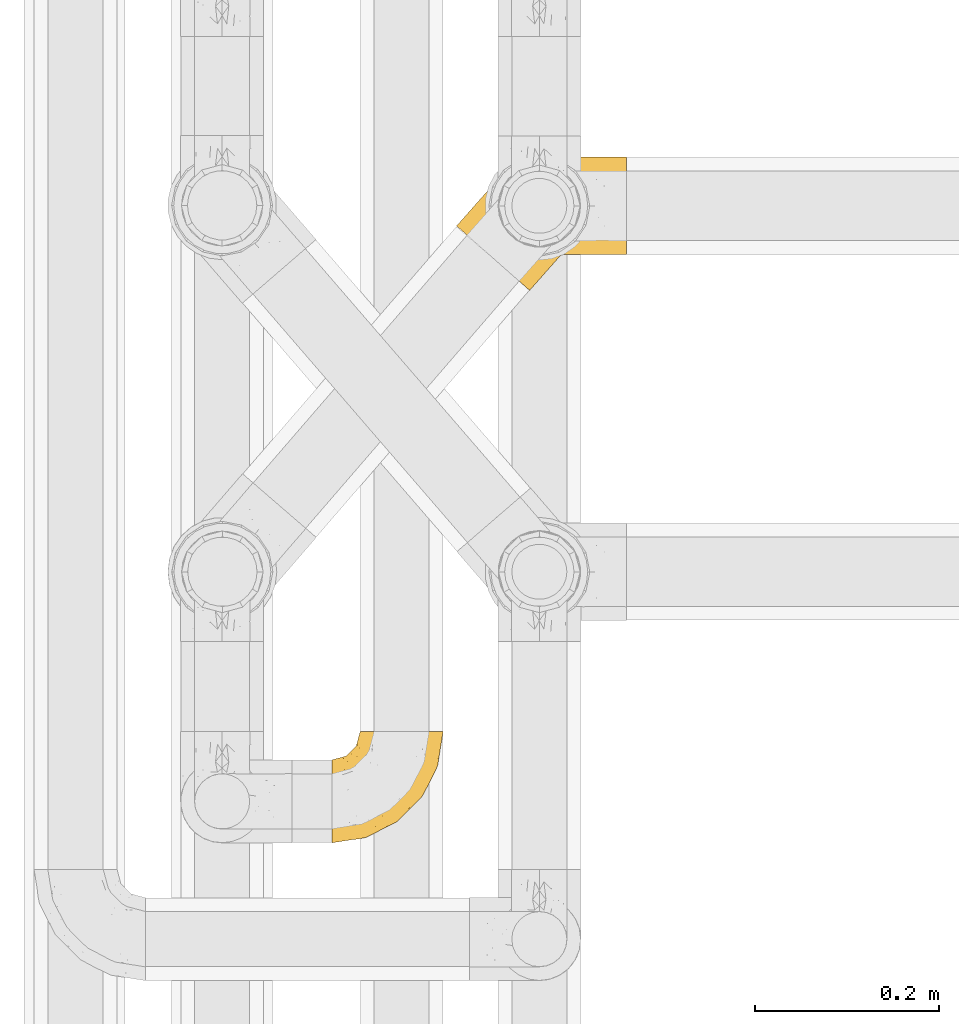
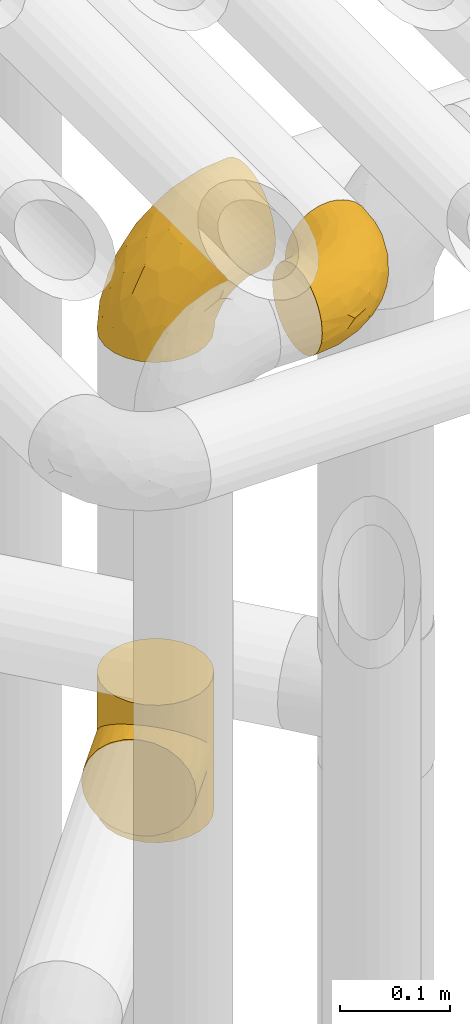
# One storey, part 232 of 827: 3 coverings.
"""IFC2X3 building model written with IfcOpenShell, lengths in millimetres."""

from ifc_helpers import new_model, entity, si_unit, converted_unit, derived_unit, direction, frame, origin, place, context, subcontext, project, spatial, faceted_brep, element, save


model = new_model("IFC2X3")

# Units and contexts
model_context = context("Model", 3, precision=0.01, world=origin(), true_north=direction((6.12303176911189e-17, 1.0)))
body_context = subcontext(model_context, "Body", "Model", "MODEL_VIEW")
ifc_project = project(units=[si_unit("LENGTHUNIT", "METRE", prefix="MILLI"), si_unit("AREAUNIT", "SQUARE_METRE"), si_unit("VOLUMEUNIT", "CUBIC_METRE"), converted_unit("PLANEANGLEUNIT", "DEGREE", entity("IfcRatioMeasure", 0.0174532925199433), si_unit("PLANEANGLEUNIT", "RADIAN"), dimensions=[0, 0, 0, 0, 0, 0, 0]), si_unit("MASSUNIT", "GRAM", prefix="KILO"), derived_unit("MASSDENSITYUNIT", [(si_unit("MASSUNIT", "GRAM", prefix="KILO"), 1), (si_unit("LENGTHUNIT", "METRE"), -3)]), derived_unit("MOMENTOFINERTIAUNIT", [(si_unit("LENGTHUNIT", "METRE"), 4)]), si_unit("TIMEUNIT", "SECOND"), si_unit("FREQUENCYUNIT", "HERTZ"), si_unit("THERMODYNAMICTEMPERATUREUNIT", "DEGREE_CELSIUS"), derived_unit("THERMALTRANSMITTANCEUNIT", [(si_unit("MASSUNIT", "GRAM", prefix="KILO"), 1), (si_unit("THERMODYNAMICTEMPERATUREUNIT", "KELVIN"), -1), (si_unit("TIMEUNIT", "SECOND"), -3)]), derived_unit("VOLUMETRICFLOWRATEUNIT", [(si_unit("LENGTHUNIT", "METRE"), 3), (si_unit("TIMEUNIT", "SECOND"), -1)]), derived_unit("MASSFLOWRATEUNIT", [(si_unit("MASSUNIT", "GRAM", prefix="KILO"), 1), (si_unit("TIMEUNIT", "SECOND"), -1)]), derived_unit("ROTATIONALFREQUENCYUNIT", [(si_unit("TIMEUNIT", "SECOND"), -1)]), si_unit("ELECTRICCURRENTUNIT", "AMPERE"), si_unit("ELECTRICVOLTAGEUNIT", "VOLT"), si_unit("POWERUNIT", "WATT"), si_unit("FORCEUNIT", "NEWTON", prefix="KILO"), si_unit("ILLUMINANCEUNIT", "LUX"), si_unit("LUMINOUSFLUXUNIT", "LUMEN"), si_unit("LUMINOUSINTENSITYUNIT", "CANDELA"), derived_unit("USERDEFINED", [(si_unit("MASSUNIT", "GRAM", prefix="KILO"), -1), (si_unit("LENGTHUNIT", "METRE"), -2), (si_unit("TIMEUNIT", "SECOND"), 3), (si_unit("LUMINOUSFLUXUNIT", "LUMEN"), 1)]), derived_unit("LINEARVELOCITYUNIT", [(si_unit("LENGTHUNIT", "METRE"), 1), (si_unit("TIMEUNIT", "SECOND"), -1)]), si_unit("PRESSUREUNIT", "PASCAL"), derived_unit("USERDEFINED", [(si_unit("LENGTHUNIT", "METRE"), -2), (si_unit("MASSUNIT", "GRAM", prefix="KILO"), 1), (si_unit("TIMEUNIT", "SECOND"), -2)]), derived_unit("LINEARFORCEUNIT", [(si_unit("MASSUNIT", "GRAM", prefix="KILO"), 1), (si_unit("LENGTHUNIT", "METRE"), 1), (si_unit("TIMEUNIT", "SECOND"), -2), (si_unit("LENGTHUNIT", "METRE"), -1)]), derived_unit("PLANARFORCEUNIT", [(si_unit("MASSUNIT", "GRAM", prefix="KILO"), 1), (si_unit("LENGTHUNIT", "METRE"), 1), (si_unit("TIMEUNIT", "SECOND"), -2), (si_unit("LENGTHUNIT", "METRE"), -2)])], contexts=[model_context])

# Site, building, storey
site_placement = place(None, origin())
site = spatial("IfcSite", under=ifc_project, at=site_placement, CompositionType="ELEMENT")
building_placement = place(site_placement, origin())
building = spatial("IfcBuilding", under=site, at=building_placement, CompositionType="ELEMENT")
storey_placement = place(building_placement, frame((0.0, 0.0, 28200.0)))
storey = spatial("IfcBuildingStorey", under=building, at=storey_placement, Name="08", CompositionType="ELEMENT", Elevation=28200.0)

# Coverings
covering_1_placement = place(storey_placement, frame((36747.44, 12284.43, 2953.25)))
element("IfcCovering", 1, at=covering_1_placement, inside=storey, Name=":ADSK_", ObjectType=":ADSK_", PredefinedType="INSULATION", context=body_context, shape_type="Brep", body=[
    faceted_brep([(87.65, 122.75, 90.76), (97.19, 122.75, 87.42), (105.75, 122.75, 82.04), (112.9, 122.75, 74.89), (118.28, 122.75, 66.33), (121.61, 122.75, 56.79), (122.75, 122.75, 46.75), (121.61, 122.75, 36.69), (118.27, 122.75, 27.15), (112.89, 122.75, 18.59), (105.74, 122.75, 11.44), (97.18, 122.75, 6.06), (87.64, 122.75, 2.73), (77.6, 122.75, 1.6), (67.54, 122.75, 2.73), (58.0, 122.75, 6.07), (49.44, 122.75, 11.45), (42.29, 122.75, 18.6), (36.91, 122.75, 27.16), (33.58, 122.75, 36.7), (32.45, 122.75, 46.75), (33.58, 122.75, 56.8), (36.92, 122.75, 66.34), (42.3, 122.75, 74.9), (49.45, 122.75, 82.05), (58.01, 122.75, 87.43), (67.55, 122.75, 90.76), (77.6, 122.75, 91.9), (1.6, 90.36, 35.06), (1.6, 85.85, 24.17), (1.6, 78.67, 14.82), (1.6, 69.32, 7.64), (1.6, 58.43, 3.13), (1.6, 46.75, 1.6), (1.6, 35.06, 3.13), (1.6, 24.17, 7.64), (1.6, 14.82, 14.82), (1.6, 7.64, 24.17), (1.6, 3.13, 35.06), (1.6, 1.6, 46.75), (1.6, 3.13, 58.43), (1.6, 7.64, 69.32), (1.6, 14.82, 78.67), (1.6, 24.17, 85.85), (1.6, 35.06, 90.36), (1.6, 46.75, 91.9), (1.6, 58.43, 90.36), (1.6, 69.32, 85.85), (1.6, 78.67, 78.67), (1.6, 85.85, 69.32), (1.6, 90.36, 58.43), (1.6, 91.9, 46.75), (99.61, 51.54, 46.75), (95.26, 47.17, 55.2), (86.21, 38.13, 46.75), (39.03, 7.52, 46.75), (30.75, 5.85, 54.53), (23.8, 5.11, 46.75), (60.8, 19.2, 59.63), (85.37, 38.98, 62.07), (73.64, 35.02, 71.86), (31.01, 8.21, 62.65), (49.14, 19.28, 71.33), (23.88, 12.19, 72.93), (82.74, 101.39, 91.2), (43.48, 34.43, 86.31), (29.47, 20.95, 80.89), (56.38, 30.74, 79.49), (72.18, 72.93, 90.68), (72.24, 56.64, 86.84), (87.6, 80.81, 87.38), (107.24, 93.43, 76.87), (101.1, 100.76, 83.73), (95.16, 74.27, 81.03), (71.81, 93.66, 91.9), (63.57, 81.33, 91.9), (55.34, 69.01, 91.9), (23.66, 40.87, 91.03), (20.55, 29.38, 87.58), (107.97, 67.05, 56.52), (116.82, 85.31, 46.75), (117.03, 93.68, 60.4), (30.68, 52.53, 91.9), (21.51, 50.71, 91.9), (12.33, 48.88, 91.9), (106.17, 72.77, 67.87), (52.37, 51.21, 90.35), (114.51, 101.18, 69.57), (119.23, 100.54, 46.75), (78.37, 48.74, 79.91), (75.46, 112.01, 91.9), (73.63, 102.83, 91.9), (101.51, 73.88, 74.99), (72.81, 24.73, 46.75), (43.01, 60.77, 91.9), (92.6, 103.08, 88.53), (91.86, 54.8, 72.65), (55.92, 16.13, 46.75), (99.01, 55.92, 62.97), (108.21, 68.42, 46.75), (32.05, 104.98, 66.2), (30.22, 108.58, 56.6), (23.37, 98.21, 59.89), (28.43, 61.56, 90.95), (16.44, 60.69, 90.22), (37.1, 100.0, 76.64), (28.88, 95.88, 71.58), (33.93, 90.81, 79.99), (50.17, 84.88, 89.54), (40.57, 73.29, 89.97), (47.62, 113.4, 81.32), (39.9, 109.8, 74.56), (47.92, 102.13, 84.15), (34.27, 67.29, 90.37), (24.65, 70.34, 87.82), (62.6, 95.15, 90.98), (66.18, 105.49, 90.96), (11.74, 71.5, 85.14), (13.89, 92.87, 58.11), (17.02, 96.03, 46.75), (15.86, 81.34, 78.39), (57.71, 107.44, 88.22), (9.11, 88.36, 66.06), (18.55, 90.43, 68.6), (34.74, 114.37, 63.78), (54.95, 98.41, 88.42), (57.35, 88.73, 90.61), (22.03, 76.89, 83.8), (24.8, 86.08, 77.98), (69.07, 112.64, 91.22), (42.31, 94.21, 83.46), (29.63, 112.22, 46.75), (28.31, 107.32, 46.75), (30.23, 79.95, 84.66), (40.13, 84.51, 86.33), (22.67, 101.67, 46.75), (12.12, 94.71, 46.75), (15.86, 81.34, 15.1), (22.03, 76.89, 9.69), (24.8, 86.08, 15.52), (30.23, 79.96, 8.83), (13.88, 92.87, 35.39), (47.61, 113.41, 12.18), (73.63, 102.83, 1.6), (66.17, 105.5, 2.53), (69.07, 112.64, 2.27), (30.22, 108.58, 36.9), (32.04, 104.98, 27.31), (23.36, 98.2, 33.62), (54.93, 98.4, 5.07), (47.91, 102.13, 9.36), (57.69, 107.44, 5.27), (9.1, 88.36, 27.43), (21.51, 50.71, 1.6), (12.33, 48.88, 1.6), (42.29, 94.22, 10.05), (37.09, 100.01, 16.87), (11.74, 71.5, 8.35), (16.44, 60.69, 3.27), (30.68, 52.53, 1.6), (28.86, 95.89, 21.94), (34.74, 114.37, 29.72), (63.57, 81.33, 1.6), (55.34, 69.01, 1.6), (50.17, 84.88, 3.96), (75.46, 112.01, 1.6), (39.89, 109.8, 18.95), (28.43, 61.56, 2.54), (34.27, 67.29, 3.12), (43.01, 60.77, 1.6), (62.59, 95.14, 2.51), (40.57, 73.29, 3.52), (40.13, 84.53, 7.17), (71.81, 93.66, 1.6), (33.92, 90.82, 13.52), (57.34, 88.73, 2.88), (24.65, 70.34, 5.67), (18.54, 90.43, 24.89), (29.47, 20.95, 12.6), (43.48, 34.43, 7.18), (56.4, 30.74, 14.0), (49.17, 19.29, 22.16), (73.69, 35.07, 21.61), (52.37, 51.21, 3.14), (72.26, 56.67, 6.65), (91.88, 54.85, 20.82), (85.36, 38.98, 31.41), (20.55, 29.38, 5.91), (23.66, 40.87, 2.46), (60.8, 19.2, 33.87), (31.02, 8.21, 30.84), (30.75, 5.85, 38.96), (23.9, 12.19, 20.56), (72.17, 72.93, 2.81), (87.59, 80.83, 6.1), (82.74, 101.39, 2.29), (117.03, 93.69, 33.08), (107.23, 93.43, 16.61), (107.97, 67.04, 36.96), (101.08, 100.76, 9.75), (106.17, 72.78, 25.61), (99.01, 55.93, 30.5), (114.5, 101.18, 23.91), (95.15, 74.27, 12.45), (101.5, 73.89, 18.49), (92.59, 103.09, 4.96), (78.38, 48.78, 13.56), (95.27, 47.19, 38.28)], [[[0, 1, 2, 3, 4, 5, 6, 7, 8, 9, 10, 11, 12, 13, 14, 15, 16, 17, 18, 19, 20, 21, 22, 23, 24, 25, 26, 27]], [[28, 29, 30, 31, 32, 33, 34, 35, 36, 37, 38, 39, 40, 41, 42, 43, 44, 45, 46, 47, 48, 49, 50, 51]], [[52, 53, 54]], [[55, 56, 57]], [[58, 59, 60]], [[61, 62, 63]], [[27, 64, 0]], [[65, 66, 67]], [[41, 40, 61]], [[68, 69, 70]], [[66, 43, 42]], [[63, 42, 41]], [[71, 72, 73]], [[72, 2, 1]], [[68, 74, 75, 76]], [[45, 44, 77]], [[43, 78, 44]], [[79, 80, 81]], [[77, 82, 83, 84, 45]], [[79, 81, 85]], [[71, 2, 72]], [[65, 86, 77]], [[4, 81, 5]], [[66, 65, 78]], [[4, 3, 87]], [[81, 88, 5]], [[63, 66, 42]], [[68, 70, 64]], [[67, 60, 89]], [[71, 3, 2]], [[64, 27, 90, 91, 74]], [[92, 71, 73]], [[40, 57, 56]], [[59, 93, 54]], [[86, 76, 94, 82]], [[1, 0, 95]], [[58, 62, 61]], [[60, 96, 89]], [[85, 81, 87]], [[56, 97, 58]], [[65, 67, 69]], [[87, 81, 4]], [[67, 89, 69]], [[61, 63, 41]], [[95, 72, 1]], [[73, 72, 70]], [[69, 73, 70]], [[73, 89, 96]], [[3, 71, 87]], [[85, 87, 71]], [[58, 61, 56]], [[59, 58, 93]], [[76, 86, 68]], [[69, 89, 73]], [[68, 86, 69]], [[65, 69, 86]], [[68, 64, 74]], [[95, 64, 70]], [[98, 79, 85]], [[79, 52, 99, 80]], [[66, 62, 67]], [[62, 58, 60]], [[62, 60, 67]], [[59, 98, 96]], [[59, 96, 60]], [[96, 85, 92]], [[88, 81, 80]], [[88, 6, 5]], [[66, 63, 62]], [[64, 95, 0]], [[72, 95, 70]], [[77, 44, 78]], [[86, 82, 77]], [[40, 39, 57]], [[96, 98, 85]], [[40, 56, 61]], [[66, 78, 43]], [[77, 78, 65]], [[79, 98, 53]], [[96, 92, 73]], [[85, 71, 92]], [[97, 56, 55]], [[97, 93, 58]], [[53, 98, 59]], [[54, 53, 59]], [[79, 53, 52]], [[100, 101, 102]], [[46, 45, 84, 83]], [[103, 104, 82]], [[82, 104, 83]], [[105, 106, 107]], [[108, 109, 76]], [[110, 111, 112]], [[103, 113, 114]], [[115, 74, 116]], [[48, 47, 117]], [[118, 102, 119]], [[49, 48, 120]], [[74, 91, 116]], [[116, 121, 115]], [[49, 122, 50]], [[123, 106, 102]], [[124, 111, 22]], [[125, 126, 115]], [[23, 22, 111]], [[24, 110, 121]], [[120, 127, 128]], [[90, 26, 129]], [[27, 26, 90]], [[121, 125, 115]], [[24, 121, 25]], [[130, 105, 107]], [[129, 25, 116]], [[21, 20, 131]], [[120, 123, 122]], [[112, 105, 130]], [[50, 118, 51]], [[21, 124, 22]], [[101, 131, 132]], [[117, 120, 48]], [[24, 23, 110]], [[127, 114, 133]], [[75, 108, 76]], [[107, 134, 130]], [[133, 114, 113]], [[129, 116, 91]], [[25, 121, 116]], [[121, 112, 125]], [[75, 74, 115]], [[101, 135, 102]], [[131, 101, 21]], [[101, 100, 124]], [[128, 127, 133]], [[119, 136, 51, 118]], [[104, 47, 46]], [[83, 104, 46]], [[117, 104, 114]], [[101, 124, 21]], [[111, 124, 100]], [[102, 118, 123]], [[133, 134, 107]], [[111, 110, 23]], [[114, 104, 103]], [[94, 76, 109]], [[121, 110, 112]], [[122, 118, 50]], [[134, 109, 108]], [[133, 107, 128]], [[112, 108, 125]], [[126, 125, 108]], [[108, 75, 126]], [[75, 115, 126]], [[109, 134, 133]], [[130, 108, 112]], [[108, 130, 134]], [[105, 112, 111]], [[111, 100, 105]], [[106, 105, 100]], [[102, 106, 100]], [[128, 106, 123]], [[90, 129, 91]], [[25, 129, 26]], [[104, 117, 47]], [[117, 114, 127]], [[82, 94, 103]], [[113, 94, 109]], [[94, 113, 103]], [[133, 113, 109]], [[106, 128, 107]], [[123, 120, 128]], [[120, 122, 49]], [[118, 122, 123]], [[135, 101, 132]], [[135, 119, 102]], [[117, 127, 120]], [[30, 29, 137]], [[138, 139, 140]], [[51, 136, 119, 141]], [[142, 17, 16]], [[143, 144, 145]], [[146, 147, 148]], [[149, 150, 151]], [[152, 29, 28]], [[33, 32, 153, 154]], [[150, 155, 156]], [[157, 31, 30]], [[153, 158, 159]], [[29, 152, 137]], [[148, 141, 119]], [[156, 160, 147]], [[148, 135, 146]], [[137, 138, 157]], [[19, 161, 146]], [[162, 163, 164]], [[14, 13, 165]], [[153, 32, 158]], [[147, 161, 166]], [[18, 17, 166]], [[167, 168, 169]], [[166, 150, 156]], [[151, 150, 142]], [[151, 170, 149]], [[151, 16, 15]], [[171, 140, 172]], [[165, 143, 145]], [[173, 170, 144]], [[142, 166, 17]], [[19, 131, 20]], [[144, 170, 151]], [[18, 161, 19]], [[173, 144, 143]], [[140, 139, 174]], [[171, 164, 163]], [[164, 172, 155]], [[151, 15, 144]], [[145, 15, 14]], [[173, 162, 170]], [[149, 175, 164]], [[19, 146, 131]], [[132, 131, 146]], [[160, 148, 147]], [[159, 158, 167]], [[135, 132, 146]], [[158, 32, 31]], [[157, 158, 31]], [[167, 158, 176]], [[166, 161, 18]], [[146, 161, 147]], [[148, 177, 141]], [[171, 168, 140]], [[171, 163, 169]], [[151, 142, 16]], [[166, 142, 150]], [[152, 141, 177]], [[51, 141, 28]], [[138, 140, 176]], [[172, 140, 174]], [[175, 149, 170]], [[164, 150, 149]], [[170, 162, 175]], [[162, 164, 175]], [[155, 172, 174]], [[171, 172, 164]], [[155, 174, 156]], [[164, 155, 150]], [[160, 156, 174]], [[147, 166, 156]], [[139, 160, 174]], [[148, 160, 177]], [[15, 145, 144]], [[165, 145, 14]], [[137, 157, 30]], [[158, 157, 176]], [[168, 167, 176]], [[169, 159, 167]], [[140, 168, 176]], [[169, 168, 171]], [[137, 177, 139]], [[160, 139, 177]], [[141, 152, 28]], [[137, 152, 177]], [[148, 119, 135]], [[157, 138, 176]], [[139, 138, 137]], [[178, 179, 180]], [[181, 180, 182]], [[179, 183, 184]], [[185, 186, 182]], [[187, 188, 179]], [[188, 33, 154, 153, 159]], [[181, 189, 190]], [[35, 34, 187]], [[191, 38, 190]], [[192, 178, 181]], [[179, 184, 180]], [[192, 190, 37]], [[37, 190, 38]], [[36, 35, 178]], [[54, 93, 186]], [[35, 187, 178]], [[193, 194, 184]], [[195, 173, 143, 165, 13]], [[195, 193, 173]], [[193, 163, 162, 173]], [[13, 12, 195]], [[8, 7, 196]], [[9, 197, 10]], [[198, 80, 99, 52]], [[196, 7, 88]], [[197, 199, 10]], [[182, 189, 181]], [[200, 198, 201]], [[200, 196, 198]], [[9, 8, 202]], [[194, 199, 203]], [[192, 37, 36]], [[80, 196, 88]], [[183, 159, 169, 163]], [[188, 34, 33]], [[202, 200, 197]], [[185, 203, 204]], [[202, 8, 196]], [[10, 199, 11]], [[12, 11, 205]], [[38, 191, 57]], [[189, 97, 191]], [[203, 199, 197]], [[205, 199, 194]], [[204, 203, 197]], [[184, 203, 206]], [[200, 202, 196]], [[197, 9, 202]], [[207, 54, 186]], [[97, 55, 191]], [[194, 203, 184]], [[183, 163, 193]], [[184, 206, 180]], [[183, 193, 184]], [[205, 195, 12]], [[193, 195, 194]], [[80, 198, 196]], [[207, 186, 201]], [[182, 180, 206]], [[181, 178, 180]], [[185, 182, 206]], [[182, 186, 189]], [[203, 185, 206]], [[185, 200, 201]], [[7, 6, 88]], [[178, 192, 36]], [[190, 192, 181]], [[199, 205, 11]], [[195, 205, 194]], [[159, 183, 188]], [[179, 188, 183]], [[57, 191, 55]], [[57, 39, 38]], [[189, 191, 190]], [[188, 187, 34]], [[178, 187, 179]], [[186, 93, 189]], [[197, 200, 204]], [[185, 204, 200]], [[189, 93, 97]], [[207, 198, 52]], [[185, 201, 186]], [[198, 207, 201]], [[54, 207, 52]]]),
])
covering_2_placement = place(storey_placement, frame((36883.36, 12885.97, 1974.0)))
element("IfcCovering", 2, at=covering_2_placement, inside=storey, Name=":ADSK_", ObjectType=":ADSK_", PredefinedType="INSULATION", context=body_context, shape_type="Brep", body=[
    faceted_brep([(47.55, 123.13, 68.86), (51.92, 128.8, 0.0), (44.18, 117.32, 0.0), (39.68, 104.22, 0.0), (41.21, 110.03, 54.84), (38.64, 94.84, 41.76), (38.72, 90.4, 0.0), (39.39, 102.67, 48.13), (51.92, 128.8, 76.0), (47.55, 123.13, 83.14), (51.92, 128.8, 152.0), (43.96, 116.86, 61.78), (39.1, 86.61, 35.89), (41.37, 76.81, 0.0), (44.45, 69.5, 26.62), (44.41, 70.59, 0.0), (47.45, 64.37, 0.0), (52.0, 59.14, 0.0), (56.55, 53.92, 0.0), (56.55, 53.92, 22.95), (52.0, 59.14, 152.0), (56.55, 53.92, 129.05), (56.55, 53.92, 152.0), (40.97, 78.08, 30.74), (49.67, 61.27, 23.9), (65.65, 47.44, 24.13), (65.65, 47.44, 127.87), (68.03, 46.18, 0.0), (75.5, 43.15, 27.43), (74.58, 43.93, 0.0), (81.13, 41.68, 0.0), (94.94, 40.73, 0.0), (94.85, 40.72, 38.42), (85.38, 41.0, 32.36), (103.7, 42.01, 45.24), (108.54, 43.38, 0.0), (111.82, 44.6, 52.57), (120.98, 49.46, 0.0), (125.73, 53.0, 68.06), (131.43, 58.55, 0.0), (119.18, 48.31, 60.22), (131.43, 58.55, 76.0), (125.73, 53.0, 83.94), (131.43, 58.55, 152.0), (135.89, 122.98, 152.0), (126.8, 133.43, 152.0), (115.31, 141.17, 152.0), (102.22, 145.67, 152.0), (88.4, 146.62, 152.0), (74.81, 143.97, 152.0), (62.36, 137.89, 152.0), (44.18, 117.32, 152.0), (39.68, 104.22, 152.0), (38.72, 90.4, 152.0), (41.37, 76.81, 152.0), (44.41, 70.59, 152.0), (47.45, 64.37, 152.0), (68.03, 46.18, 152.0), (74.58, 43.93, 152.0), (81.13, 41.68, 152.0), (94.94, 40.73, 152.0), (108.54, 43.38, 152.0), (120.98, 49.46, 152.0), (139.16, 70.03, 152.0), (143.66, 83.13, 152.0), (144.62, 96.95, 152.0), (141.97, 110.54, 152.0), (62.36, 137.89, 0.0), (74.81, 143.97, 0.0), (88.4, 146.62, 0.0), (102.22, 145.67, 0.0), (115.31, 141.17, 0.0), (126.8, 133.43, 0.0), (135.89, 122.98, 0.0), (141.97, 110.54, 0.0), (144.62, 96.95, 0.0), (143.66, 83.13, 0.0), (139.16, 70.03, 0.0), (43.96, 116.86, 90.22), (41.21, 110.03, 97.16), (39.39, 102.67, 103.87), (38.64, 94.84, 110.24), (39.1, 86.61, 116.11), (40.97, 78.08, 121.26), (44.45, 69.5, 125.38), (49.67, 61.27, 128.1), (75.5, 43.15, 124.57), (85.38, 41.0, 119.64), (94.85, 40.72, 113.58), (111.82, 44.6, 99.43), (119.18, 48.31, 91.78), (103.7, 42.01, 106.76), (1.6, 71.85, 76.0), (2.95, 70.65, 62.27), (6.92, 67.14, 49.47), (13.24, 61.56, 38.49), (21.47, 54.29, 30.06), (26.27, 50.05, 27.41), (31.06, 45.81, 24.76), (36.21, 41.27, 23.85), (41.35, 36.72, 22.95), (51.64, 27.63, 24.76), (56.43, 23.39, 27.41), (61.23, 19.16, 30.06), (69.46, 11.88, 38.49), (75.78, 6.3, 49.47), (79.75, 2.79, 62.27), (81.1, 1.6, 76.0), (79.75, 2.79, 89.73), (75.78, 6.3, 102.53), (69.46, 11.88, 113.51), (61.23, 19.16, 121.94), (56.43, 23.39, 124.59), (51.64, 27.63, 127.24), (41.35, 36.72, 129.05), (36.21, 41.27, 128.15), (31.06, 45.81, 127.24), (26.27, 50.05, 124.59), (21.47, 54.29, 121.94), (13.24, 61.56, 113.51), (6.92, 67.14, 102.53), (2.95, 70.65, 89.73)], [[[0, 1, 2]], [[2, 3, 4]], [[5, 3, 6]], [[5, 7, 3]], [[0, 8, 1]], [[8, 9, 10]], [[4, 11, 2]], [[7, 4, 3]], [[0, 2, 11]], [[12, 6, 13]], [[14, 13, 15, 16]], [[17, 18, 19]], [[20, 21, 22]], [[23, 12, 13]], [[24, 14, 16]], [[24, 17, 19]], [[24, 16, 17]], [[23, 13, 14]], [[6, 12, 5]], [[25, 19, 18]], [[21, 26, 22]], [[25, 18, 27]], [[28, 27, 29, 30]], [[28, 25, 27]], [[31, 32, 33]], [[28, 30, 33]], [[33, 30, 31]], [[34, 31, 35]], [[36, 35, 37]], [[38, 37, 39]], [[36, 34, 35]], [[38, 40, 37]], [[41, 38, 39]], [[42, 41, 43]], [[36, 37, 40]], [[31, 34, 32]], [[44, 45, 46, 47, 48, 49, 50, 10, 51, 52, 53, 54, 55, 56, 20, 22, 57, 58, 59, 60, 61, 62, 43, 63, 64, 65, 66]], [[1, 67, 68, 69, 70, 71, 72, 73, 74, 75, 76, 77, 39, 37, 35, 31, 30, 29, 27, 18, 17, 16, 15, 13, 6, 3, 2]], [[70, 69, 48, 47]], [[45, 72, 71, 46]], [[46, 71, 70, 47]], [[49, 68, 67, 50]], [[1, 8, 10, 50, 67]], [[48, 69, 68, 49]], [[78, 79, 51]], [[9, 78, 51]], [[10, 9, 51]], [[52, 80, 81]], [[52, 51, 79]], [[52, 81, 53]], [[80, 52, 79]], [[82, 83, 54]], [[84, 56, 55, 54]], [[84, 85, 56]], [[21, 20, 85]], [[83, 84, 54]], [[53, 82, 54]], [[85, 20, 56]], [[82, 53, 81]], [[26, 86, 57]], [[59, 87, 60]], [[86, 59, 58, 57]], [[86, 87, 59]], [[22, 26, 57]], [[87, 88, 60]], [[89, 90, 62]], [[90, 42, 62]], [[60, 91, 61]], [[91, 60, 88]], [[89, 61, 91]], [[89, 62, 61]], [[42, 43, 62]], [[41, 39, 77, 63, 43]], [[63, 77, 76, 64]], [[76, 75, 65, 64]], [[65, 75, 74, 66]], [[66, 74, 73, 44]], [[44, 73, 72, 45]], [[92, 93, 94, 95, 96, 97, 98, 99, 100, 101, 102, 103, 104, 105, 106, 107, 108, 109, 110, 111, 112, 113, 114, 115, 116, 117, 118, 119, 120, 121]], [[24, 99, 98]], [[96, 95, 12]], [[14, 98, 97, 96]], [[19, 99, 24]], [[19, 100, 99]], [[23, 14, 96]], [[12, 23, 96]], [[24, 98, 14]], [[95, 5, 12]], [[7, 5, 94]], [[94, 5, 95]], [[4, 94, 93]], [[0, 93, 92]], [[4, 7, 94]], [[0, 11, 93]], [[8, 0, 92]], [[4, 93, 11]], [[9, 92, 121]], [[121, 120, 79]], [[81, 120, 119]], [[81, 80, 120]], [[9, 8, 92]], [[79, 78, 121]], [[80, 79, 120]], [[9, 121, 78]], [[82, 119, 118]], [[84, 118, 117, 116]], [[115, 114, 21]], [[83, 82, 118]], [[85, 84, 116]], [[85, 115, 21]], [[85, 116, 115]], [[83, 118, 84]], [[119, 82, 81]], [[26, 21, 114]], [[26, 114, 113]], [[86, 113, 112, 111]], [[86, 26, 113]], [[110, 88, 87]], [[86, 111, 87]], [[87, 111, 110]], [[91, 110, 109]], [[89, 109, 108]], [[42, 108, 107]], [[89, 91, 109]], [[42, 90, 108]], [[41, 42, 107]], [[89, 108, 90]], [[110, 91, 88]], [[38, 107, 106]], [[106, 105, 36]], [[34, 105, 104]], [[34, 36, 105]], [[38, 41, 107]], [[36, 40, 106]], [[38, 106, 40]], [[33, 104, 103]], [[28, 103, 102, 101]], [[25, 101, 100]], [[33, 32, 104]], [[25, 28, 101]], [[19, 25, 100]], [[33, 103, 28]], [[104, 32, 34]]]),
])
covering_3_placement = place(storey_placement, frame((36920.39, 12925.0, 2503.4)))
element("IfcCovering", 3, at=covering_3_placement, inside=storey, Name=":ADSK_", ObjectType=":ADSK_", PredefinedType="INSULATION", context=body_context, shape_type="Brep", body=[
    faceted_brep([(149.65, 66.44, 148.32), (149.65, 54.65, 149.65), (149.65, 42.84, 148.31), (149.65, 31.62, 144.39), (149.65, 21.56, 138.06), (149.65, 13.16, 129.66), (149.65, 6.84, 119.6), (149.65, 2.92, 108.39), (149.65, 1.6, 96.6), (149.65, 2.93, 84.79), (149.65, 6.85, 73.57), (149.65, 13.18, 63.51), (149.65, 21.58, 55.11), (149.65, 31.64, 48.79), (149.65, 42.85, 44.87), (149.65, 54.65, 43.55), (149.65, 66.46, 44.88), (149.65, 77.67, 48.8), (149.65, 87.73, 55.13), (149.65, 96.13, 63.53), (149.65, 102.45, 73.59), (149.65, 106.37, 84.8), (149.65, 107.7, 96.6), (149.65, 106.36, 108.41), (149.65, 102.44, 119.62), (149.65, 96.11, 129.68), (149.65, 87.71, 138.08), (149.65, 77.65, 144.4), (105.89, 40.91, 1.6), (100.59, 28.12, 1.6), (92.16, 17.13, 1.6), (81.17, 8.7, 1.6), (68.38, 3.4, 1.6), (54.65, 1.6, 1.6), (40.91, 3.4, 1.6), (28.12, 8.7, 1.6), (17.13, 17.13, 1.6), (8.7, 28.12, 1.6), (3.4, 40.91, 1.6), (1.6, 54.65, 1.6), (3.4, 68.38, 1.6), (8.7, 81.17, 1.6), (17.13, 92.16, 1.6), (28.12, 100.59, 1.6), (40.91, 105.89, 1.6), (54.65, 107.7, 1.6), (68.38, 105.89, 1.6), (81.17, 100.59, 1.6), (92.16, 92.16, 1.6), (100.59, 81.17, 1.6), (105.89, 68.38, 1.6), (107.7, 54.65, 1.6), (14.05, 85.53, 27.97), (9.45, 73.42, 37.09), (22.36, 83.77, 58.27), (4.7, 64.22, 27.13), (6.64, 54.65, 39.91), (81.47, 96.72, 109.11), (56.83, 93.36, 94.41), (64.02, 84.47, 110.94), (34.04, 71.37, 89.69), (21.43, 54.65, 75.62), (44.96, 54.65, 106.28), (49.8, 103.47, 60.12), (35.43, 100.91, 41.41), (42.1, 99.1, 63.22), (43.59, 105.43, 32.05), (57.88, 106.79, 52.13), (91.8, 89.81, 123.27), (88.01, 79.59, 129.32), (115.65, 81.29, 138.3), (18.94, 74.01, 62.95), (12.83, 64.14, 55.89), (24.96, 94.75, 37.4), (111.33, 54.65, 144.6), (113.8, 70.74, 142.66), (60.89, 68.3, 117.85), (86.24, 66.05, 134.01), (65.84, 100.73, 89.25), (124.58, 106.78, 103.34), (121.36, 103.6, 113.52), (72.79, 107.7, 57.43), (66.04, 107.7, 44.19), (59.29, 107.7, 30.95), (73.26, 106.07, 77.98), (121.69, 90.59, 132.66), (109.82, 97.43, 121.52), (40.11, 84.51, 86.93), (36.57, 93.3, 68.4), (93.81, 107.7, 78.45), (83.3, 107.7, 67.94), (136.6, 107.7, 94.53), (120.29, 107.7, 91.95), (99.11, 106.79, 93.36), (107.05, 107.7, 85.2), (91.12, 103.47, 101.45), (75.62, 54.65, 129.81), (56.97, 107.7, 16.27), (126.65, 76.99, 42.46), (116.55, 84.28, 40.4), (120.09, 91.11, 49.71), (76.06, 106.26, 39.4), (83.69, 102.6, 31.26), (71.88, 106.08, 27.7), (66.92, 106.56, 16.7), (110.43, 105.36, 70.67), (121.31, 106.74, 81.69), (81.0, 101.59, 16.68), (113.32, 54.65, 22.57), (111.09, 54.65, 14.26), (109.14, 67.71, 17.68), (95.86, 91.36, 19.58), (99.07, 94.33, 33.49), (106.92, 87.1, 33.01), (131.39, 65.84, 40.69), (136.98, 54.65, 40.15), (128.67, 54.65, 37.93), (117.07, 68.92, 31.04), (96.39, 100.82, 45.29), (106.61, 79.83, 23.55), (103.72, 77.13, 11.36), (92.14, 105.9, 59.1), (107.13, 101.53, 57.42), (98.03, 106.72, 68.96), (88.38, 97.75, 20.38), (130.66, 103.08, 72.46), (135.45, 106.39, 83.66), (123.57, 98.1, 60.66), (137.75, 95.02, 61.01), (133.2, 86.9, 51.85), (138.8, 74.42, 46.07), (120.99, 54.65, 30.25), (84.53, 105.28, 46.65), (108.72, 92.87, 43.0), (95.86, 17.93, 19.58), (130.67, 6.22, 72.44), (109.13, 41.58, 17.67), (93.81, 1.6, 78.45), (98.02, 2.57, 68.97), (110.43, 3.94, 70.65), (131.4, 43.46, 40.69), (126.66, 32.32, 42.45), (117.08, 40.38, 31.04), (108.74, 16.44, 42.99), (96.31, 8.47, 45.18), (99.11, 15.01, 33.46), (123.58, 11.21, 60.64), (107.12, 7.78, 57.37), (72.79, 1.6, 57.43), (66.04, 1.6, 44.19), (76.07, 3.04, 39.35), (56.97, 1.6, 16.27), (66.92, 2.73, 16.7), (120.29, 1.6, 91.95), (107.05, 1.6, 85.2), (121.26, 2.55, 81.68), (84.46, 3.98, 46.68), (83.69, 6.69, 31.26), (81.0, 7.7, 16.68), (71.88, 3.21, 27.7), (137.76, 14.28, 60.99), (133.21, 22.42, 51.84), (116.58, 25.02, 40.41), (120.1, 18.18, 49.72), (138.81, 34.89, 46.06), (136.6, 1.6, 94.53), (103.72, 32.17, 11.35), (106.96, 22.23, 33.02), (135.44, 2.91, 83.65), (88.38, 11.54, 20.38), (83.3, 1.6, 67.94), (92.12, 3.38, 59.12), (106.6, 29.46, 23.53), (59.29, 1.6, 30.95), (22.36, 25.52, 58.27), (14.05, 23.76, 27.97), (24.96, 14.54, 37.4), (35.43, 8.38, 41.41), (4.71, 45.07, 27.21), (9.45, 35.87, 37.09), (11.79, 45.14, 53.2), (57.88, 2.5, 52.13), (124.57, 2.51, 103.34), (121.37, 5.68, 113.5), (91.12, 5.82, 101.45), (56.83, 15.93, 94.41), (81.48, 12.54, 109.08), (64.05, 24.81, 110.95), (99.11, 2.5, 93.36), (73.26, 3.22, 77.98), (43.59, 3.86, 32.05), (19.5, 35.85, 64.63), (91.8, 19.47, 123.25), (121.7, 18.68, 132.65), (88.04, 29.68, 129.32), (123.34, 27.95, 139.96), (60.89, 40.99, 117.85), (34.04, 37.92, 89.69), (109.85, 11.85, 121.51), (42.1, 10.19, 63.23), (65.78, 8.55, 89.17), (113.81, 38.53, 142.66), (36.57, 15.99, 68.4), (40.12, 24.79, 86.94), (49.8, 5.82, 60.12), (86.08, 40.56, 133.2)], [[[0, 1, 2, 3, 4, 5, 6, 7, 8, 9, 10, 11, 12, 13, 14, 15, 16, 17, 18, 19, 20, 21, 22, 23, 24, 25, 26, 27]], [[28, 29, 30, 31, 32, 33, 34, 35, 36, 37, 38, 39, 40, 41, 42, 43, 44, 45, 46, 47, 48, 49, 50, 51]], [[52, 53, 54]], [[55, 39, 56]], [[57, 58, 59]], [[60, 61, 62]], [[63, 64, 65]], [[66, 63, 67]], [[68, 69, 70]], [[53, 71, 54]], [[41, 40, 53]], [[53, 72, 71]], [[73, 42, 52]], [[42, 41, 52]], [[74, 0, 75]], [[69, 76, 77]], [[43, 73, 64]], [[45, 44, 66]], [[57, 78, 58]], [[23, 79, 80]], [[67, 81, 82, 83]], [[67, 84, 81]], [[24, 23, 80]], [[25, 85, 26]], [[86, 85, 25]], [[42, 73, 43]], [[0, 27, 75]], [[25, 24, 86]], [[70, 26, 85]], [[0, 74, 1]], [[68, 85, 86]], [[66, 64, 63]], [[60, 59, 87]], [[54, 87, 88]], [[76, 60, 62]], [[84, 89, 90, 81]], [[79, 22, 91, 92]], [[77, 74, 75]], [[93, 92, 94, 89]], [[80, 86, 24]], [[40, 55, 53]], [[76, 59, 60]], [[93, 84, 95]], [[76, 62, 96]], [[55, 72, 53]], [[70, 27, 26]], [[75, 70, 69]], [[78, 84, 63]], [[93, 79, 92]], [[95, 86, 80]], [[77, 76, 96]], [[59, 69, 68]], [[57, 68, 86]], [[68, 57, 59]], [[59, 58, 87]], [[76, 69, 59]], [[88, 87, 58]], [[87, 54, 71]], [[86, 95, 57]], [[78, 57, 95]], [[84, 78, 95]], [[78, 63, 65]], [[58, 78, 65]], [[54, 88, 73]], [[84, 93, 89]], [[79, 95, 80]], [[79, 93, 95]], [[22, 79, 23]], [[66, 83, 97, 45]], [[84, 67, 63]], [[83, 66, 67]], [[64, 44, 43]], [[64, 66, 44]], [[65, 73, 88]], [[53, 52, 41]], [[73, 52, 54]], [[73, 65, 64]], [[65, 88, 58]], [[39, 55, 40]], [[72, 55, 56]], [[56, 61, 72]], [[60, 72, 61]], [[72, 60, 71]], [[87, 71, 60]], [[27, 70, 75]], [[68, 70, 85]], [[74, 77, 96]], [[69, 77, 75]], [[98, 99, 100]], [[46, 45, 97]], [[101, 102, 103]], [[103, 104, 83]], [[105, 94, 106]], [[107, 103, 102]], [[108, 109, 51, 110]], [[111, 112, 113]], [[114, 115, 116]], [[47, 104, 107]], [[110, 117, 108]], [[49, 48, 111]], [[102, 118, 112]], [[119, 120, 111]], [[50, 49, 120]], [[121, 122, 118]], [[105, 123, 89]], [[124, 48, 107]], [[20, 19, 125]], [[121, 81, 90]], [[117, 119, 99]], [[21, 20, 126]], [[22, 21, 91]], [[105, 125, 127]], [[110, 51, 50]], [[19, 128, 125]], [[16, 15, 115]], [[129, 98, 100]], [[126, 91, 21]], [[128, 129, 127]], [[122, 123, 105]], [[114, 117, 98]], [[17, 16, 130]], [[18, 128, 19]], [[129, 18, 17]], [[125, 106, 126]], [[115, 114, 16]], [[130, 129, 17]], [[114, 98, 130]], [[117, 116, 131, 108]], [[99, 119, 113]], [[122, 121, 123]], [[92, 126, 106]], [[105, 127, 122]], [[132, 121, 118]], [[114, 130, 16]], [[129, 130, 98]], [[50, 120, 110]], [[129, 128, 18]], [[125, 128, 127]], [[125, 126, 20]], [[91, 126, 92]], [[105, 89, 94]], [[105, 106, 125]], [[94, 92, 106]], [[100, 122, 127]], [[118, 122, 133]], [[112, 118, 133]], [[132, 118, 102]], [[132, 102, 101]], [[81, 121, 132]], [[82, 103, 83]], [[132, 101, 81]], [[104, 47, 46]], [[124, 107, 102]], [[48, 47, 107]], [[113, 112, 133]], [[112, 111, 124]], [[99, 113, 133]], [[111, 113, 119]], [[99, 133, 100]], [[117, 99, 98]], [[122, 100, 133]], [[127, 129, 100]], [[103, 82, 101]], [[81, 101, 82]], [[112, 124, 102]], [[48, 124, 111]], [[104, 103, 107]], [[46, 97, 104]], [[111, 120, 49]], [[83, 104, 97]], [[110, 120, 119]], [[117, 110, 119]], [[116, 117, 114]], [[123, 90, 89]], [[90, 123, 121]], [[30, 29, 134]], [[11, 10, 135]], [[51, 109, 108, 136]], [[137, 138, 139]], [[140, 141, 142]], [[143, 144, 145]], [[146, 139, 147]], [[148, 149, 150]], [[151, 32, 152]], [[153, 154, 155]], [[156, 150, 157]], [[158, 157, 159]], [[108, 142, 136]], [[31, 158, 152]], [[160, 161, 12]], [[162, 163, 143]], [[140, 142, 116]], [[142, 141, 162]], [[14, 164, 140]], [[14, 140, 115]], [[9, 8, 165]], [[160, 12, 11]], [[141, 164, 161]], [[13, 12, 161]], [[14, 115, 15]], [[28, 166, 29]], [[135, 139, 146]], [[141, 163, 162]], [[135, 146, 160]], [[143, 167, 162]], [[29, 166, 134]], [[116, 142, 108, 131]], [[165, 153, 168]], [[10, 9, 168]], [[168, 135, 10]], [[138, 147, 139]], [[158, 169, 157]], [[14, 13, 164]], [[116, 115, 140]], [[145, 167, 143]], [[135, 160, 11]], [[168, 153, 155]], [[138, 170, 171]], [[157, 144, 156]], [[147, 144, 143]], [[161, 164, 13]], [[140, 164, 141]], [[142, 172, 136]], [[136, 172, 166]], [[161, 160, 146]], [[165, 168, 9]], [[155, 139, 135]], [[139, 154, 137]], [[168, 155, 135]], [[139, 155, 154]], [[144, 147, 171]], [[163, 147, 143]], [[156, 144, 171]], [[157, 169, 145]], [[171, 148, 156]], [[173, 159, 149]], [[159, 157, 150]], [[152, 159, 173]], [[159, 152, 158]], [[31, 30, 158]], [[169, 30, 134]], [[157, 145, 144]], [[167, 134, 172]], [[134, 167, 145]], [[172, 142, 162]], [[162, 167, 172]], [[163, 141, 161]], [[161, 146, 163]], [[147, 163, 146]], [[148, 150, 156]], [[149, 159, 150]], [[30, 169, 158]], [[145, 169, 134]], [[151, 33, 32]], [[31, 152, 32]], [[152, 173, 151]], [[28, 51, 136]], [[134, 166, 172]], [[28, 136, 166]], [[147, 138, 171]], [[170, 138, 137]], [[170, 148, 171]], [[174, 175, 176]], [[35, 34, 177]], [[178, 179, 180]], [[181, 173, 149, 148]], [[182, 183, 184]], [[185, 186, 187]], [[188, 189, 137]], [[190, 33, 151, 173]], [[191, 179, 174]], [[34, 190, 177]], [[39, 38, 178]], [[192, 193, 194]], [[4, 3, 195]], [[175, 179, 37]], [[38, 37, 179]], [[35, 176, 36]], [[196, 62, 197]], [[181, 190, 173]], [[37, 36, 175]], [[183, 6, 198]], [[189, 148, 170, 137]], [[185, 199, 200]], [[3, 2, 201]], [[202, 185, 203]], [[8, 7, 182]], [[200, 184, 186]], [[183, 7, 6]], [[181, 189, 204]], [[200, 189, 184]], [[5, 198, 6]], [[187, 203, 185]], [[195, 3, 201]], [[205, 196, 194]], [[62, 61, 197]], [[186, 198, 192]], [[180, 179, 191]], [[2, 1, 74]], [[198, 193, 192]], [[193, 5, 4]], [[194, 193, 195]], [[2, 74, 201]], [[5, 193, 198]], [[205, 74, 96]], [[188, 137, 154, 153]], [[62, 196, 96]], [[56, 178, 180]], [[198, 184, 183]], [[184, 188, 182]], [[203, 197, 191]], [[205, 194, 201]], [[187, 192, 194]], [[192, 187, 186]], [[194, 196, 187]], [[197, 187, 196]], [[197, 203, 187]], [[202, 174, 176]], [[200, 186, 185]], [[184, 198, 186]], [[199, 185, 202]], [[189, 200, 204]], [[174, 202, 203]], [[176, 177, 199]], [[189, 181, 148]], [[190, 181, 204]], [[190, 204, 177]], [[190, 34, 33]], [[188, 153, 182]], [[189, 188, 184]], [[182, 153, 165, 8]], [[183, 182, 7]], [[199, 177, 204]], [[35, 177, 176]], [[176, 175, 36]], [[179, 175, 174]], [[200, 199, 204]], [[176, 199, 202]], [[203, 191, 174]], [[180, 197, 61]], [[197, 180, 191]], [[61, 56, 180]], [[39, 178, 56]], [[38, 179, 178]], [[194, 195, 201]], [[4, 195, 193]], [[74, 205, 201]], [[96, 196, 205]]]),
])

save(model, "model.ifc")
